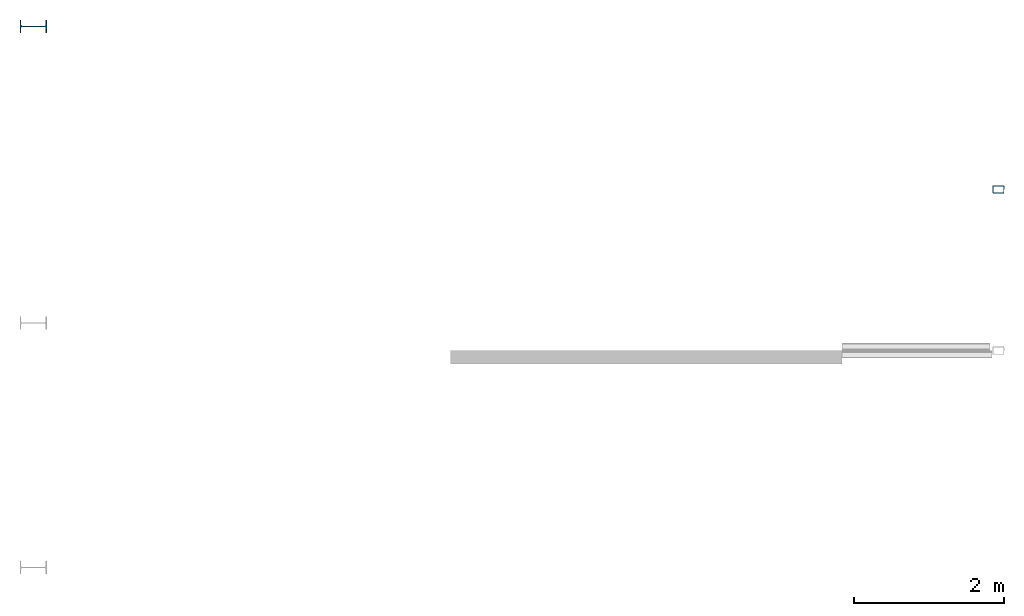
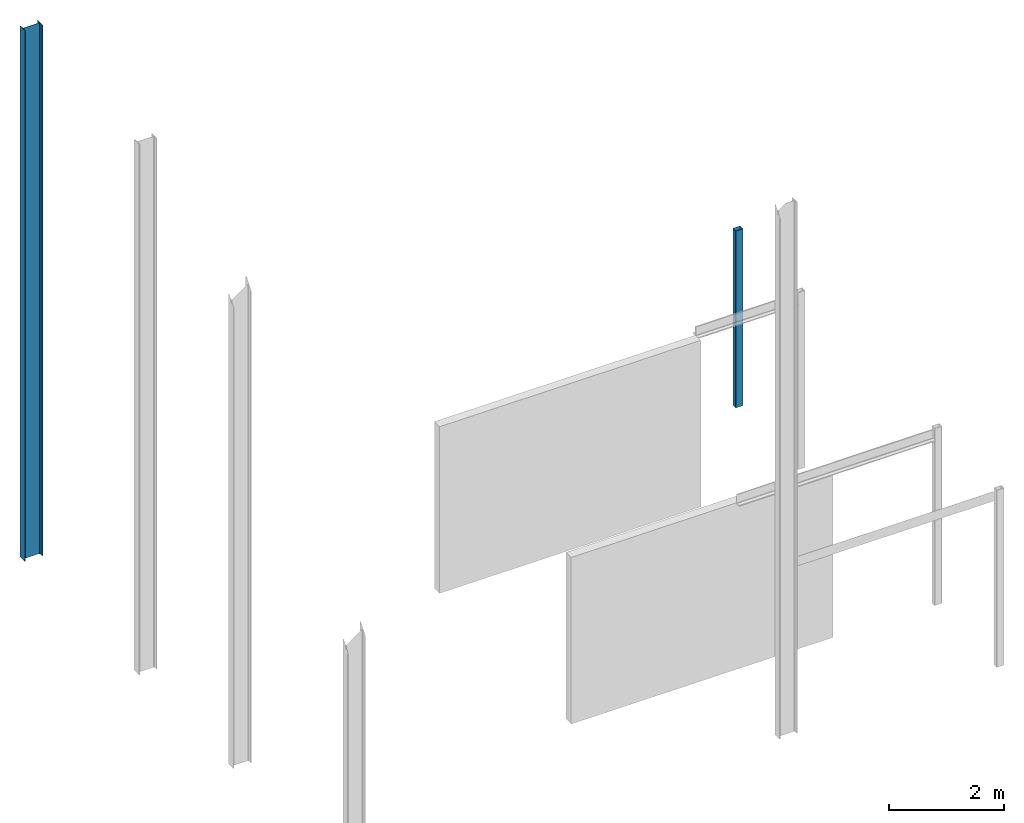
# One storey, part 3 of 4: 2 columns.
"""IFC2X3 building model written with IfcOpenShell, lengths in millimetres."""

from ifc_helpers import new_model, entity, si_unit, converted_unit, frame, frame_2d, origin, place, context, project, spatial, polyline, circle_curve, parameter, trimmed, segment, composite_curve, outline, extrude, source, transform, mapped, material, type_object, type_shapes, element, save


model = new_model("IFC2X3")

# Units and contexts
model_context = context("Model", 3, precision=1e-06, world=origin())
plan_context = context("Plan", 3, precision=1e-06, world=origin())
ifc_project = project(units=[si_unit("LENGTHUNIT", "METRE", prefix="MILLI"), si_unit("AREAUNIT", "SQUARE_METRE", prefix="MILLI"), si_unit("VOLUMEUNIT", "CUBIC_METRE", prefix="MILLI"), converted_unit("PLANEANGLEUNIT", "DEGREE", entity("IfcRatioMeasure", 0.01745329251994328), si_unit("PLANEANGLEUNIT", "RADIAN"), dimensions=[0, 0, 0, 0, 0, 0, 0]), si_unit("TIMEUNIT", "SECOND")], contexts=[model_context, plan_context])

# Site, building, storey
site_placement = place(None, origin())
site = spatial("IfcSite", under=ifc_project, at=site_placement, CompositionType="ELEMENT")
building_placement = place(None, origin())
building = spatial("IfcBuilding", under=site, at=building_placement, CompositionType="ELEMENT")
storey_placement = place(building_placement, origin())
storey = spatial("IfcBuildingStorey", under=building, at=storey_placement, Name="Level 1", CompositionType="ELEMENT", Elevation=0.0)

# Columns
ifc_material_1 = material(Name="Metal - Steel - 250 MPa")
column_type_1 = type_object("IfcColumnType", Name="IPE360", PredefinedType="COLUMN")
shared_shape_1 = source(origin(), model_context, "Body", "SweptSolid", [
    extrude(outline(composite_curve([segment(polyline([(-85.0, -180.0), (85.0, -180.0)]), True, "CONTINUOUS"), segment(polyline([(85.0, -180.0), (85.0, -167.3)]), True, "CONTINUOUS"), segment(polyline([(85.0, -167.3), (22.0, -167.3)]), True, "CONTINUOUS"), segment(trimmed(circle_curve(frame_2d((22.0, -149.3), x_axis=(-1.0, 0.0)), 18.0), [parameter(3.562221243239142e-13)], [parameter(90.00000000000044)], True, "PARAMETER"), False, "CONTINUOUS"), segment(polyline([(4.0, -149.3), (4.0, 149.3)]), True, "CONTINUOUS"), segment(trimmed(circle_curve(frame_2d((22.0, 149.3), x_axis=(-1.0, 0.0)), 18.0), [parameter(270.0000000000003)], [parameter(3.562221243239142e-13)], True, "PARAMETER"), False, "CONTINUOUS"), segment(polyline([(22.0, 167.3), (85.0, 167.3)]), True, "CONTINUOUS"), segment(polyline([(85.0, 167.3), (85.0, 180.0)]), True, "CONTINUOUS"), segment(polyline([(85.0, 180.0), (-85.0, 180.0)]), True, "CONTINUOUS"), segment(polyline([(-85.0, 180.0), (-85.0, 167.3)]), True, "CONTINUOUS"), segment(polyline([(-85.0, 167.3), (-22.0, 167.3)]), True, "CONTINUOUS"), segment(trimmed(circle_curve(frame_2d((-22.0, 149.3), x_axis=(-1.0, 0.0)), 18.0), [parameter(180.0)], [parameter(270.0000000000001)], True, "PARAMETER"), False, "CONTINUOUS"), segment(polyline([(-4.0, 149.3), (-4.0, -149.3)]), True, "CONTINUOUS"), segment(trimmed(circle_curve(frame_2d((-22.0, -149.3), x_axis=(-1.0, 0.0)), 18.0), [parameter(90.00000000000044)], [parameter(180.0000000000002)], True, "PARAMETER"), False, "CONTINUOUS"), segment(polyline([(-22.0, -167.3), (-85.0, -167.3)]), True, "CONTINUOUS"), segment(polyline([(-85.0, -167.3), (-85.0, -180.0)]), True, "CONTINUOUS")], self_intersect=False)), frame((0.0, 0.0, 0.0), z_axis=(0.0, 0.0, 1.0), x_axis=(-1.0, 0.0, 0.0)), (0.0, 0.0, 1.0), 11250.0),
])
type_shapes(column_type_1, [shared_shape_1])
column_1_placement = place(storey_placement, frame((-24822.54977824739, 11398.40101993982, 0.0), z_axis=(0.0, 0.0, 1.0), x_axis=(0.0, 1.0, 0.0)))
element("IfcColumn", 1, at=column_1_placement, inside=storey, type_object=column_type_1, material=ifc_material_1, Name="IPE-Column:IPE360:IPE360", ObjectType="IPE360", context=model_context, shape_type="MappedRepresentation", body=[
    mapped(shared_shape_1, transform((0.0, 0.0, 0.0), scale=1.0)),
])
ifc_material_2 = material(Name="Metal - Steel - 345 MPa")
column_type_2 = type_object("IfcColumnType", Name="150x100x5", PredefinedType="COLUMN")
shared_shape_2 = source(origin(), model_context, "Body", "SweptSolid", [
    extrude(outline(composite_curve([segment(polyline([(-40.0, -75.0), (40.0, -75.0)]), True, "CONTINUOUS"), segment(trimmed(circle_curve(frame_2d((40.0, -65.0), x_axis=(-1.0, 0.0)), 9.999999999997998), [parameter(90.00000000000009)], [parameter(180.0000000000002)], True, "PARAMETER"), True, "CONTINUOUS"), segment(polyline([(50.0, -65.0), (50.0, 65.0)]), True, "CONTINUOUS"), segment(trimmed(circle_curve(frame_2d((40.0, 65.0), x_axis=(-1.0, 0.0)), 9.99999999999999), [parameter(179.9999999999999)], [parameter(269.9999999999997)], True, "PARAMETER"), True, "CONTINUOUS"), segment(polyline([(40.0, 75.0), (-40.0, 75.0)]), True, "CONTINUOUS"), segment(trimmed(circle_curve(frame_2d((-40.0, 65.0), x_axis=(-1.0, 0.0)), 10.00000000000288), [parameter(269.9999999999995)], [parameter(359.9999999999996)], True, "PARAMETER"), True, "CONTINUOUS"), segment(polyline([(-50.0, 65.0), (-50.0, -65.0)]), True, "CONTINUOUS"), segment(trimmed(circle_curve(frame_2d((-40.0, -65.0), x_axis=(-1.0, 0.0)), 9.999999999996726), [parameter(359.9999999999996)], [parameter(89.99999999999963)], True, "PARAMETER"), True, "CONTINUOUS")], self_intersect=False), holes=[composite_curve([segment(trimmed(circle_curve(frame_2d((-40.0, -65.0), x_axis=(-1.0, 0.0)), 4.999999999996471), [parameter(0.0)], [parameter(89.99999999999999)], True, "PARAMETER"), False, "CONTINUOUS"), segment(polyline([(-45.0, -65.0), (-45.0, 65.0)]), True, "CONTINUOUS"), segment(trimmed(circle_curve(frame_2d((-40.0, 65.0), x_axis=(-1.0, 0.0)), 4.999999999998176), [parameter(270.0)], [parameter(359.9999999999999)], True, "PARAMETER"), False, "CONTINUOUS"), segment(polyline([(-40.0, 70.0), (40.0, 70.0)]), True, "CONTINUOUS"), segment(trimmed(circle_curve(frame_2d((40.0, 65.0), x_axis=(-1.0, 0.0)), 5.000000000001551), [parameter(180.0000000000001)], [parameter(270.0)], True, "PARAMETER"), False, "CONTINUOUS"), segment(polyline([(45.0, 65.0), (45.0, -65.0)]), True, "CONTINUOUS"), segment(trimmed(circle_curve(frame_2d((40.0, -65.0), x_axis=(-1.0, 0.0)), 5.000000000000011), [parameter(90.0000000000005)], [parameter(179.9999999999998)], True, "PARAMETER"), False, "CONTINUOUS"), segment(polyline([(40.0, -70.0), (-40.0, -70.0)]), True, "CONTINUOUS")], self_intersect=False)]), frame((0.0, 0.0, 0.0), z_axis=(0.0, 0.0, 1.0), x_axis=(-1.0, 0.0, 0.0)), (0.0, 0.0, 1.0), 3750.000000000001),
])
type_shapes(column_type_2, [shared_shape_2])
column_2_placement = place(storey_placement, frame((-11917.18323242557, 9217.072263559809, 0.0), z_axis=(0.0, 0.0, 1.0), x_axis=(0.0, 1.0, 0.0)))
element("IfcColumn", 2, at=column_2_placement, inside=storey, type_object=column_type_2, material=ifc_material_2, ObjectType="150x100x5", context=model_context, shape_type="MappedRepresentation", body=[
    mapped(shared_shape_2, transform((0.0, 0.0, 0.0), scale=1.0)),
])

save(model, "model.ifc")
